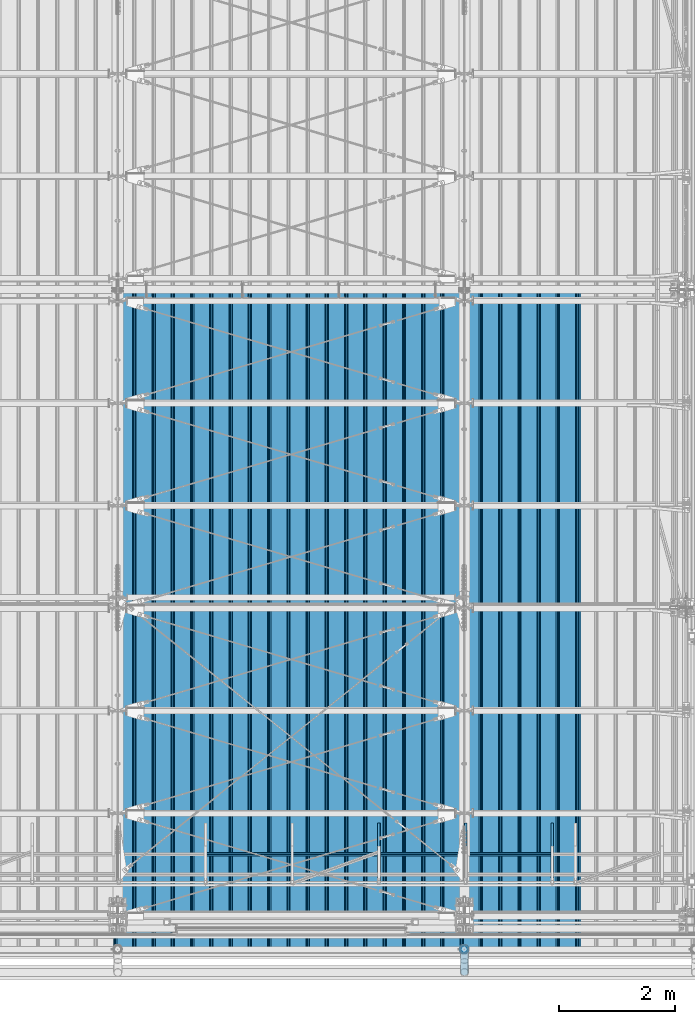
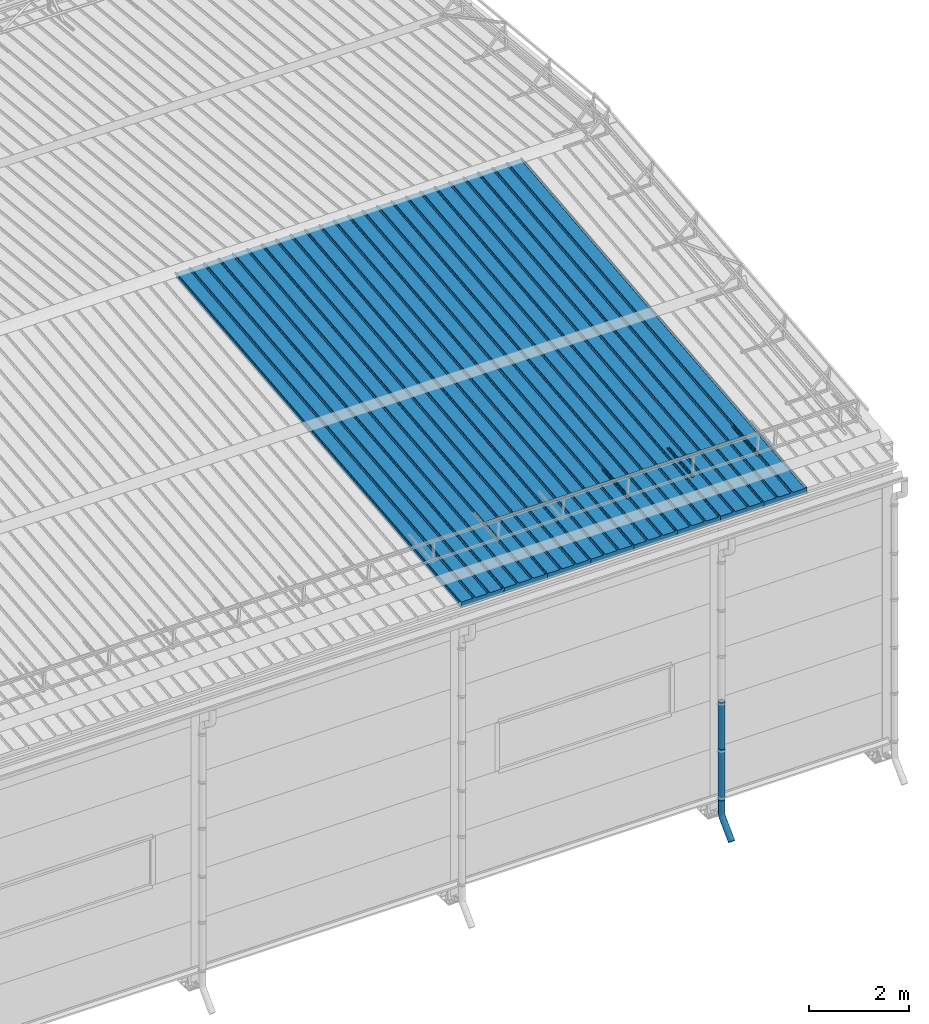
# One storey, part 68 of 709: 15 beams, 15 elements without a shape of their own.
"""IFC4 building model written with IfcOpenShell, lengths in millimetres."""

import ifcopenshell
import ifcopenshell.guid

model = None  # the IFC model being written
_history = None  # IfcOwnerHistory: only IFC2X3 demands one
_inside = {}  # id of a spatial element -> (the spatial element, [elements in it])
_under = {}  # id of a project, library or spatial element -> (it, [spatial elements below it])
_declared = {}  # id of a project -> (the project, [libraries it declares])
_typed = {}  # id of a type object -> (the type object, [elements of that type])
_made_of = {}  # id of a material, layer set ... -> (it, [elements and type objects made of it])


def new_model(schema):
    """Start an empty IFC model of exactly this schema.

    Asked for "IFC4X3", IfcOpenShell would pick the latest addendum, in which some entities
    have other attributes; the version numbers below select the first issue.
    IFC2X3 requires an IfcOwnerHistory on every rooted entity: one is made here for all.
    """
    global model, _history
    if schema == "IFC4X3":
        model = ifcopenshell.file(schema_version=(4, 3, 0, 0))
    else:
        model = ifcopenshell.file(schema=schema)
    _inside.clear()
    _under.clear()
    _declared.clear()
    _typed.clear()
    _made_of.clear()
    _history = None
    if model.schema == "IFC2X3":
        org = make("IfcOrganization", Name="unknown")
        user = make(
            "IfcPersonAndOrganization",
            ThePerson=make("IfcPerson", FamilyName="unknown"),
            TheOrganization=org,
        )
        app = make(
            "IfcApplication",
            ApplicationDeveloper=org,
            Version="unknown",
            ApplicationFullName="unknown",
            ApplicationIdentifier="unknown",
        )
        _history = make(
            "IfcOwnerHistory",
            OwningUser=user,
            OwningApplication=app,
            ChangeAction="ADDED",
            CreationDate=0,
        )
    return model


def make(cls, **values):
    """One entity of the class cls with the attributes given. An attribute that is None is left unset."""
    return model.create_entity(
        cls, **{name: value for name, value in values.items() if value is not None}
    )


def entity(cls, *values):
    """Any entity or typed value of the class cls, its attributes in the order of the schema. None: left unset."""
    e = model.create_entity(cls)
    for i, value in enumerate(values):
        if value is not None:
            e[i] = value
    return e


def rooted(cls, **values):
    """An entity with a GlobalId (a new one), such as an element, a storey or a relation."""
    return make(cls, GlobalId=ifcopenshell.guid.new(), OwnerHistory=_history, **values)


def si_unit(unit_type, name, prefix=None):
    """IfcSIUnit, for example si_unit("LENGTHUNIT", "METRE", prefix="MILLI")."""
    return make("IfcSIUnit", UnitType=unit_type, Prefix=prefix, Name=name)


def assignment(units):
    """IfcUnitAssignment: the units of a project."""
    return None if units is None else make("IfcUnitAssignment", Units=units)


def point(xyz):
    """IfcCartesianPoint."""
    return None if xyz is None else make("IfcCartesianPoint", Coordinates=xyz)


def direction(xyz):
    """IfcDirection."""
    return None if xyz is None else make("IfcDirection", DirectionRatios=xyz)


def frame(location, z_axis=None, x_axis=None):
    """IfcAxis2Placement3D, a coordinate frame: its origin and axes. An axis left out is left unset."""
    return make(
        "IfcAxis2Placement3D",
        Location=point(location),
        Axis=direction(z_axis),
        RefDirection=direction(x_axis),
    )


def origin_with_axes():
    """The frame at (0, 0, 0) with the z axis (0, 0, 1) and the x axis (1, 0, 0) written out."""
    return frame((0.0, 0.0, 0.0), z_axis=(0.0, 0.0, 1.0), x_axis=(1.0, 0.0, 0.0))


def place(relative_to, where):
    """IfcLocalPlacement: puts the frame where relative to a parent placement (None: the world)."""
    return make(
        "IfcLocalPlacement", PlacementRelTo=relative_to, RelativePlacement=where
    )


def context(
    kind, dimensions, precision=None, world=None, true_north=None, identifier=None
):
    """IfcGeometricRepresentationContext, for example the 3D "Model" context."""
    return make(
        "IfcGeometricRepresentationContext",
        ContextIdentifier=identifier,
        ContextType=kind,
        CoordinateSpaceDimension=dimensions,
        Precision=precision,
        WorldCoordinateSystem=world,
        TrueNorth=true_north,
    )


def subcontext(parent, identifier, kind, view, scale=None):
    """IfcGeometricRepresentationSubContext, for example "Body" below "Model"."""
    return make(
        "IfcGeometricRepresentationSubContext",
        ContextIdentifier=identifier,
        ContextType=kind,
        ParentContext=parent,
        TargetScale=scale,
        TargetView=view,
    )


def project(units=None, contexts=None):
    """IfcProject with its units and contexts."""
    return rooted(
        "IfcProject",
        Name="project",
        RepresentationContexts=contexts,
        UnitsInContext=assignment(units),
    )


def spatial(cls, under=None, at=None, **own):
    """A site, building, storey or space (cls), placed at a placement, below another one or the project."""
    s = rooted(cls, ObjectPlacement=at, **own)
    if under is not None:
        _under.setdefault(under.id(), (under, []))[1].append(s)
    return s


def point_list(points):
    """IfcCartesianPointList2D or 3D."""
    cls = (
        "IfcCartesianPointList2D" if len(points[0]) == 2 else "IfcCartesianPointList3D"
    )
    return make(cls, CoordList=points)


def line(*indices):
    """IfcLineIndex: a straight run through numbered points of an indexed curve."""
    return model.create_entity("IfcLineIndex", indices)


def indexed_curve(points, segments=None, self_intersect=None):
    """IfcIndexedPolyCurve: lines and arcs through numbered points (the first is 1)."""
    return make(
        "IfcIndexedPolyCurve",
        Points=point_list(points),
        Segments=segments,
        SelfIntersect=self_intersect,
    )


def outline(outer, holes=None, kind="AREA"):
    """IfcArbitraryClosedProfileDef: a profile drawn as a closed curve; with holes, ...WithVoids."""
    if holes is None:
        return make("IfcArbitraryClosedProfileDef", ProfileType=kind, OuterCurve=outer)
    return make(
        "IfcArbitraryProfileDefWithVoids",
        ProfileType=kind,
        OuterCurve=outer,
        InnerCurves=holes,
    )


def extrude(swept, where, along, depth):
    """IfcExtrudedAreaSolid: the profile swept, set in the frame where, extruded along a direction by depth."""
    return make(
        "IfcExtrudedAreaSolid",
        SweptArea=swept,
        Position=where,
        ExtrudedDirection=direction(along),
        Depth=depth,
    )


def shape(context_of_items, identifier, shape_type, items):
    """IfcShapeRepresentation: the items that make up one representation, for example the "Body"."""
    return make(
        "IfcShapeRepresentation",
        ContextOfItems=context_of_items,
        RepresentationIdentifier=identifier,
        RepresentationType=shape_type,
        Items=items,
    )


def material(Name=None, Category=None):
    """IfcMaterial."""
    return make("IfcMaterial", Name=Name, Category=Category)


def made_of(thing, what):
    """Note that an element or type object is made of a material, layer set ...; save() writes the relation."""
    if what is not None:
        _made_of.setdefault(what.id(), (what, []))[1].append(thing)
    return thing


def element(
    cls,
    number,
    at=None,
    inside=None,
    cuts=None,
    type_object=None,
    material=None,
    context=None,
    identifier="Body",
    shape_type=None,
    held_by="IfcProductDefinitionShape",
    body=None,
    shapes=None,
    **own,
):
    """One element of the class cls, such as IfcWall. Its Tag is "e" and its number.

    at: its placement. inside: the storey or other place that contains it. cuts: it is an
    opening in that element (IfcRelVoidsElement). A single representation is given by context,
    identifier, shape_type and body (its items); several are given by shapes. held_by: the class
    of the entity that holds the representations. save() writes the other relations.
    """
    e = rooted(cls, Tag="e%d" % number, ObjectPlacement=at, **own)
    if body is not None:
        shapes = [shape(context, identifier, shape_type, body)]
    if shapes is not None:
        e.Representation = make(held_by, Representations=shapes)
    if inside is not None:
        _inside.setdefault(inside.id(), (inside, []))[1].append(e)
    if cuts is not None:
        rooted(
            "IfcRelVoidsElement", RelatingBuildingElement=cuts, RelatedOpeningElement=e
        )
    if type_object is not None:
        _typed.setdefault(type_object.id(), (type_object, []))[1].append(e)
    return made_of(e, material)


def aggregate(whole, parts):
    """IfcRelAggregates: a whole, such as a stair, and the parts it consists of."""
    return rooted("IfcRelAggregates", RelatingObject=whole, RelatedObjects=parts)


def save(model, path):
    """Write the relations noted so far, then the file.

    IfcRelAggregates (storeys below a building ...), IfcRelContainedInSpatialStructure (elements
    in a storey), IfcRelDefinesByType, IfcRelAssociatesMaterial and IfcRelDeclares: one each for
    every whole, place, type object, material and project.
    """
    for whole, parts in _under.values():
        aggregate(whole, parts)
    for where, things in _inside.values():
        rooted(
            "IfcRelContainedInSpatialStructure",
            RelatedElements=things,
            RelatingStructure=where,
        )
    for kind, things in _typed.values():
        rooted("IfcRelDefinesByType", RelatedObjects=things, RelatingType=kind)
    for what, things in _made_of.values():
        rooted("IfcRelAssociatesMaterial", RelatedObjects=things, RelatingMaterial=what)
    for by, libraries in _declared.values():
        rooted("IfcRelDeclares", RelatingContext=by, RelatedDefinitions=libraries)
    model.write(path)


model = new_model("IFC4")

# Units and contexts
model_context = context("Model", 3, precision=0.2, world=origin_with_axes(), true_north=direction((0.0, 1.0)))
body_context = subcontext(model_context, "Body", "Model", "MODEL_VIEW")
ifc_project = project(units=[si_unit("LENGTHUNIT", "METRE", prefix="MILLI"), si_unit("AREAUNIT", "SQUARE_METRE"), si_unit("VOLUMEUNIT", "CUBIC_METRE"), si_unit("MASSUNIT", "GRAM", prefix="KILO"), si_unit("TIMEUNIT", "SECOND"), si_unit("PLANEANGLEUNIT", "RADIAN"), si_unit("SOLIDANGLEUNIT", "STERADIAN"), si_unit("THERMODYNAMICTEMPERATUREUNIT", "DEGREE_CELSIUS"), si_unit("LUMINOUSINTENSITYUNIT", "LUMEN")], contexts=[model_context])

# Site, building, storey
site_placement = place(None, origin_with_axes())
site = spatial("IfcSite", under=ifc_project, at=site_placement, CompositionType="ELEMENT")
building_placement = place(site_placement, origin_with_axes())
building = spatial("IfcBuilding", under=site, at=building_placement, Name="Undefined", CompositionType="ELEMENT")
storey_placement = place(building_placement, origin_with_axes())
storey = spatial("IfcBuildingStorey", under=building, at=storey_placement, Name="Undefined", CompositionType="ELEMENT", Elevation=0.0)

# Assembly, beam
assembly_1_placement = place(storey_placement, frame((47452.44, -410.89541, 7279.78979), z_axis=(1.0, 0.0, 0.0), x_axis=(0.0, 0.9950371902, 0.099503719)))
assembly_1 = element("IfcElementAssembly", 1, at=assembly_1_placement, inside=storey)
ifc_material_1 = material(Name="Insulation", Category="Insulation")
beam_1_placement = place(assembly_1_placement, origin_with_axes())
beam_1 = element("IfcBeam", 2, at=beam_1_placement, material=ifc_material_1, ObjectType="P-99", context=body_context, shape_type="SolidModel", body=[
    extrude(outline(indexed_curve([(-509.8453, 89.5), (-490.1547, 89.5), (-471.67949, 57.5), (-471.67949, -88.5), (-436.67949, -88.5), (-436.67949, -91.5), (562.55841, -91.5), (562.55841, -89.5), (527.55841, -89.5), (527.55841, 57.5), (510.2379, 88.5), (489.7621, 88.5), (472.44159, 58.5), (196.71923, 58.5), (177.66667, 91.5), (155.66667, 91.5), (136.61411, 58.5), (-136.61411, 58.5), (-155.66667, 91.5), (-177.66667, 91.5), (-196.71923, 58.5), (-469.94744, 58.5), (-489.0, 91.5), (-511.0, 91.5), (-527.16581, 63.5), (-525.43376, 62.5)], segments=[line(1, 2, 3, 4, 5, 6, 7, 8, 9, 10, 11, 12, 13, 14, 15, 16, 17, 18, 19, 20, 21, 22, 23, 24, 25, 26, 1)])), frame((0.0, 0.0, 0.0), z_axis=(-1.0, 0.0, 0.0), x_axis=(0.0, 0.0, 1.0)), (0.0, 0.0, -1.0), 11459.0),
])
aggregate(assembly_1, [beam_1])

assembly_2_placement = place(storey_placement, frame((46452.44, -410.89541, 7279.78979), z_axis=(1.0, 0.0, 0.0), x_axis=(0.0, 0.9950371902, 0.099503719)))
assembly_2 = element("IfcElementAssembly", 3, at=assembly_2_placement, inside=storey)
beam_2_placement = place(assembly_2_placement, origin_with_axes())
beam_2 = element("IfcBeam", 4, at=beam_2_placement, material=ifc_material_1, ObjectType="P-99", context=body_context, shape_type="SolidModel", body=[
    extrude(outline(indexed_curve([(-509.8453, 89.5), (-490.1547, 89.5), (-471.67949, 57.5), (-471.67949, -88.5), (-436.67949, -88.5), (-436.67949, -91.5), (562.55841, -91.5), (562.55841, -89.5), (527.55841, -89.5), (527.55841, 57.5), (510.2379, 88.5), (489.7621, 88.5), (472.44159, 58.5), (196.71923, 58.5), (177.66667, 91.5), (155.66667, 91.5), (136.61411, 58.5), (-136.61411, 58.5), (-155.66667, 91.5), (-177.66667, 91.5), (-196.71923, 58.5), (-469.94744, 58.5), (-489.0, 91.5), (-511.0, 91.5), (-527.16581, 63.5), (-525.43376, 62.5)], segments=[line(1, 2, 3, 4, 5, 6, 7, 8, 9, 10, 11, 12, 13, 14, 15, 16, 17, 18, 19, 20, 21, 22, 23, 24, 25, 26, 1)])), frame((0.0, 0.0, 0.0), z_axis=(-1.0, 0.0, 0.0), x_axis=(0.0, 0.0, 1.0)), (0.0, 0.0, -1.0), 11459.0),
])
aggregate(assembly_2, [beam_2])

assembly_3_placement = place(storey_placement, frame((45452.44, -410.89541, 7279.78979), z_axis=(1.0, 0.0, 0.0), x_axis=(0.0, 0.9950371902, 0.099503719)))
assembly_3 = element("IfcElementAssembly", 5, at=assembly_3_placement, inside=storey)
beam_3_placement = place(assembly_3_placement, origin_with_axes())
beam_3 = element("IfcBeam", 6, at=beam_3_placement, material=ifc_material_1, ObjectType="P-99", context=body_context, shape_type="SolidModel", body=[
    extrude(outline(indexed_curve([(-509.8453, 89.5), (-490.1547, 89.5), (-471.67949, 57.5), (-471.67949, -88.5), (-436.67949, -88.5), (-436.67949, -91.5), (562.55841, -91.5), (562.55841, -89.5), (527.55841, -89.5), (527.55841, 57.5), (510.2379, 88.5), (489.7621, 88.5), (472.44159, 58.5), (196.71923, 58.5), (177.66667, 91.5), (155.66667, 91.5), (136.61411, 58.5), (-136.61411, 58.5), (-155.66667, 91.5), (-177.66667, 91.5), (-196.71923, 58.5), (-469.94744, 58.5), (-489.0, 91.5), (-511.0, 91.5), (-527.16581, 63.5), (-525.43376, 62.5)], segments=[line(1, 2, 3, 4, 5, 6, 7, 8, 9, 10, 11, 12, 13, 14, 15, 16, 17, 18, 19, 20, 21, 22, 23, 24, 25, 26, 1)])), frame((0.0, 0.0, 0.0), z_axis=(-1.0, 0.0, 0.0), x_axis=(0.0, 0.0, 1.0)), (0.0, 0.0, -1.0), 11459.0),
])
aggregate(assembly_3, [beam_3])

assembly_4_placement = place(storey_placement, frame((44452.44, -410.89541, 7279.78979), z_axis=(1.0, 0.0, 0.0), x_axis=(0.0, 0.9950371902, 0.099503719)))
assembly_4 = element("IfcElementAssembly", 7, at=assembly_4_placement, inside=storey)
beam_4_placement = place(assembly_4_placement, origin_with_axes())
beam_4 = element("IfcBeam", 8, at=beam_4_placement, material=ifc_material_1, ObjectType="P-99", context=body_context, shape_type="SolidModel", body=[
    extrude(outline(indexed_curve([(-509.8453, 89.5), (-490.1547, 89.5), (-471.67949, 57.5), (-471.67949, -88.5), (-436.67949, -88.5), (-436.67949, -91.5), (562.55841, -91.5), (562.55841, -89.5), (527.55841, -89.5), (527.55841, 57.5), (510.2379, 88.5), (489.7621, 88.5), (472.44159, 58.5), (196.71923, 58.5), (177.66667, 91.5), (155.66667, 91.5), (136.61411, 58.5), (-136.61411, 58.5), (-155.66667, 91.5), (-177.66667, 91.5), (-196.71923, 58.5), (-469.94744, 58.5), (-489.0, 91.5), (-511.0, 91.5), (-527.16581, 63.5), (-525.43376, 62.5)], segments=[line(1, 2, 3, 4, 5, 6, 7, 8, 9, 10, 11, 12, 13, 14, 15, 16, 17, 18, 19, 20, 21, 22, 23, 24, 25, 26, 1)])), frame((0.0, 0.0, 0.0), z_axis=(-1.0, 0.0, 0.0), x_axis=(0.0, 0.0, 1.0)), (0.0, 0.0, -1.0), 11459.0),
])
aggregate(assembly_4, [beam_4])

assembly_5_placement = place(storey_placement, frame((43452.44, -410.89541, 7279.78979), z_axis=(1.0, 0.0, 0.0), x_axis=(0.0, 0.9950371902, 0.099503719)))
assembly_5 = element("IfcElementAssembly", 9, at=assembly_5_placement, inside=storey)
beam_5_placement = place(assembly_5_placement, origin_with_axes())
beam_5 = element("IfcBeam", 10, at=beam_5_placement, material=ifc_material_1, ObjectType="P-99", context=body_context, shape_type="SolidModel", body=[
    extrude(outline(indexed_curve([(-509.8453, 89.5), (-490.1547, 89.5), (-471.67949, 57.5), (-471.67949, -88.5), (-436.67949, -88.5), (-436.67949, -91.5), (562.55841, -91.5), (562.55841, -89.5), (527.55841, -89.5), (527.55841, 57.5), (510.2379, 88.5), (489.7621, 88.5), (472.44159, 58.5), (196.71923, 58.5), (177.66667, 91.5), (155.66667, 91.5), (136.61411, 58.5), (-136.61411, 58.5), (-155.66667, 91.5), (-177.66667, 91.5), (-196.71923, 58.5), (-469.94744, 58.5), (-489.0, 91.5), (-511.0, 91.5), (-527.16581, 63.5), (-525.43376, 62.5)], segments=[line(1, 2, 3, 4, 5, 6, 7, 8, 9, 10, 11, 12, 13, 14, 15, 16, 17, 18, 19, 20, 21, 22, 23, 24, 25, 26, 1)])), frame((0.0, 0.0, 0.0), z_axis=(-1.0, 0.0, 0.0), x_axis=(0.0, 0.0, 1.0)), (0.0, 0.0, -1.0), 11459.0),
])
aggregate(assembly_5, [beam_5])

assembly_6_placement = place(storey_placement, frame((42452.44, -410.89541, 7279.78979), z_axis=(1.0, 0.0, 0.0), x_axis=(0.0, 0.9950371902, 0.099503719)))
assembly_6 = element("IfcElementAssembly", 11, at=assembly_6_placement, inside=storey)
beam_6_placement = place(assembly_6_placement, origin_with_axes())
beam_6 = element("IfcBeam", 12, at=beam_6_placement, material=ifc_material_1, ObjectType="P-99", context=body_context, shape_type="SolidModel", body=[
    extrude(outline(indexed_curve([(-509.8453, 89.5), (-490.1547, 89.5), (-471.67949, 57.5), (-471.67949, -88.5), (-436.67949, -88.5), (-436.67949, -91.5), (562.55841, -91.5), (562.55841, -89.5), (527.55841, -89.5), (527.55841, 57.5), (510.2379, 88.5), (489.7621, 88.5), (472.44159, 58.5), (196.71923, 58.5), (177.66667, 91.5), (155.66667, 91.5), (136.61411, 58.5), (-136.61411, 58.5), (-155.66667, 91.5), (-177.66667, 91.5), (-196.71923, 58.5), (-469.94744, 58.5), (-489.0, 91.5), (-511.0, 91.5), (-527.16581, 63.5), (-525.43376, 62.5)], segments=[line(1, 2, 3, 4, 5, 6, 7, 8, 9, 10, 11, 12, 13, 14, 15, 16, 17, 18, 19, 20, 21, 22, 23, 24, 25, 26, 1)])), frame((0.0, 0.0, 0.0), z_axis=(-1.0, 0.0, 0.0), x_axis=(0.0, 0.0, 1.0)), (0.0, 0.0, -1.0), 11459.0),
])
aggregate(assembly_6, [beam_6])

assembly_7_placement = place(storey_placement, frame((41452.44, -410.89541, 7279.78979), z_axis=(1.0, 0.0, 0.0), x_axis=(0.0, 0.9950371902, 0.099503719)))
assembly_7 = element("IfcElementAssembly", 13, at=assembly_7_placement, inside=storey)
beam_7_placement = place(assembly_7_placement, origin_with_axes())
beam_7 = element("IfcBeam", 14, at=beam_7_placement, material=ifc_material_1, ObjectType="P-99", context=body_context, shape_type="SolidModel", body=[
    extrude(outline(indexed_curve([(-509.8453, 89.5), (-490.1547, 89.5), (-471.67949, 57.5), (-471.67949, -88.5), (-436.67949, -88.5), (-436.67949, -91.5), (562.55841, -91.5), (562.55841, -89.5), (527.55841, -89.5), (527.55841, 57.5), (510.2379, 88.5), (489.7621, 88.5), (472.44159, 58.5), (196.71923, 58.5), (177.66667, 91.5), (155.66667, 91.5), (136.61411, 58.5), (-136.61411, 58.5), (-155.66667, 91.5), (-177.66667, 91.5), (-196.71923, 58.5), (-469.94744, 58.5), (-489.0, 91.5), (-511.0, 91.5), (-527.16581, 63.5), (-525.43376, 62.5)], segments=[line(1, 2, 3, 4, 5, 6, 7, 8, 9, 10, 11, 12, 13, 14, 15, 16, 17, 18, 19, 20, 21, 22, 23, 24, 25, 26, 1)])), frame((0.0, 0.0, 0.0), z_axis=(-1.0, 0.0, 0.0), x_axis=(0.0, 0.0, 1.0)), (0.0, 0.0, -1.0), 11459.0),
])
aggregate(assembly_7, [beam_7])

assembly_8_placement = place(storey_placement, frame((40452.44, -410.89541, 7279.78979), z_axis=(1.0, 0.0, 0.0), x_axis=(0.0, 0.9950371902, 0.099503719)))
assembly_8 = element("IfcElementAssembly", 15, at=assembly_8_placement, inside=storey)
beam_8_placement = place(assembly_8_placement, origin_with_axes())
beam_8 = element("IfcBeam", 16, at=beam_8_placement, material=ifc_material_1, ObjectType="P-99", context=body_context, shape_type="SolidModel", body=[
    extrude(outline(indexed_curve([(-509.8453, 89.5), (-490.1547, 89.5), (-471.67949, 57.5), (-471.67949, -88.5), (-436.67949, -88.5), (-436.67949, -91.5), (562.55841, -91.5), (562.55841, -89.5), (527.55841, -89.5), (527.55841, 57.5), (510.2379, 88.5), (489.7621, 88.5), (472.44159, 58.5), (196.71923, 58.5), (177.66667, 91.5), (155.66667, 91.5), (136.61411, 58.5), (-136.61411, 58.5), (-155.66667, 91.5), (-177.66667, 91.5), (-196.71923, 58.5), (-469.94744, 58.5), (-489.0, 91.5), (-511.0, 91.5), (-527.16581, 63.5), (-525.43376, 62.5)], segments=[line(1, 2, 3, 4, 5, 6, 7, 8, 9, 10, 11, 12, 13, 14, 15, 16, 17, 18, 19, 20, 21, 22, 23, 24, 25, 26, 1)])), frame((0.0, 0.0, 0.0), z_axis=(-1.0, 0.0, 0.0), x_axis=(0.0, 0.0, 1.0)), (0.0, 0.0, -1.0), 11459.0),
])
aggregate(assembly_8, [beam_8])

assembly_9_placement = place(storey_placement, frame((44520.0, 768.92298, 7577.16191), z_axis=(0.0, -0.099503719, 0.9950371902), x_axis=(0.0, 0.9950371902, 0.099503719)))
assembly_9 = element("IfcElementAssembly", 17, at=assembly_9_placement, inside=storey)
ifc_material_2 = material(Name="Steel_Undefined", Category="STEEL")
beam_9_placement = place(assembly_9_placement, origin_with_axes())
beam_9 = element("IfcBeam", 18, at=beam_9_placement, material=ifc_material_2, ObjectType="601", context=body_context, shape_type="SolidModel", body=[
    extrude(outline(indexed_curve([(-20.0, -25.0), (20.0, -25.0), (20.0, -22.5), (-17.5, -22.5), (-17.5, 22.5), (20.0, 22.5), (20.0, 25.0), (-20.0, 25.0)], segments=[line(1, 2, 3, 4, 5, 6, 7, 8, 1)])), frame((0.0, 0.0, 0.0), z_axis=(-1.0, 0.0, 0.0), x_axis=(0.0, 0.0, 1.0)), (0.0, 0.0, -1.0), 1000.0),
])
aggregate(assembly_9, [beam_9])

assembly_10_placement = place(storey_placement, frame((46020.0, 768.92298, 7577.16191), z_axis=(0.0, -0.099503719, 0.9950371902), x_axis=(0.0, 0.9950371902, 0.099503719)))
assembly_10 = element("IfcElementAssembly", 19, at=assembly_10_placement, inside=storey)
beam_10_placement = place(assembly_10_placement, origin_with_axes())
beam_10 = element("IfcBeam", 20, at=beam_10_placement, material=ifc_material_2, ObjectType="601", context=body_context, shape_type="SolidModel", body=[
    extrude(outline(indexed_curve([(-20.0, -25.0), (20.0, -25.0), (20.0, -22.5), (-17.5, -22.5), (-17.5, 22.5), (20.0, 22.5), (20.0, 25.0), (-20.0, 25.0)], segments=[line(1, 2, 3, 4, 5, 6, 7, 8, 1)])), frame((0.0, 0.0, 0.0), z_axis=(-1.0, 0.0, 0.0), x_axis=(0.0, 0.0, 1.0)), (0.0, 0.0, -1.0), 1000.0),
])
aggregate(assembly_10, [beam_10])

assembly_11_placement = place(storey_placement, frame((41520.0, 1225.80867, 7759.0901), z_axis=(0.0, 0.6332377902, 0.7739572992), x_axis=(1.0, 0.0, 0.0)))
assembly_11 = element("IfcElementAssembly", 21, at=assembly_11_placement, inside=storey)
beam_11_placement = place(assembly_11_placement, origin_with_axes())
beam_11 = element("IfcBeam", 22, at=beam_11_placement, material=ifc_material_2, ObjectType="606", context=body_context, shape_type="SolidModel", body=[
    extrude(outline(indexed_curve([(-20.0, -25.0), (20.0, -25.0), (20.0, -22.5), (-17.5, -22.5), (-17.5, 22.5), (20.0, 22.5), (20.0, 25.0), (-20.0, 25.0)], segments=[line(1, 2, 3, 4, 5, 6, 7, 8, 1)])), frame((0.0, 0.0, 0.0), z_axis=(-1.0, 0.0, 0.0), x_axis=(0.0, 0.0, 1.0)), (0.0, 0.0, -1.0), 6000.0),
])
aggregate(assembly_11, [beam_11])

assembly_12_placement = place(storey_placement, frame((47520.0, 768.92298, 7577.16191), z_axis=(0.0, -0.099503719, 0.9950371902), x_axis=(0.0, 0.9950371902, 0.099503719)))
assembly_12 = element("IfcElementAssembly", 23, at=assembly_12_placement, inside=storey)
beam_12_placement = place(assembly_12_placement, origin_with_axes())
beam_12 = element("IfcBeam", 24, at=beam_12_placement, material=ifc_material_2, ObjectType="601", context=body_context, shape_type="SolidModel", body=[
    extrude(outline(indexed_curve([(-20.0, -25.0), (20.0, -25.0), (20.0, -22.5), (-17.5, -22.5), (-17.5, 22.5), (20.0, 22.5), (20.0, 25.0), (-20.0, 25.0)], segments=[line(1, 2, 3, 4, 5, 6, 7, 8, 1)])), frame((0.0, 0.0, 0.0), z_axis=(-1.0, 0.0, 0.0), x_axis=(0.0, 0.0, 1.0)), (0.0, 0.0, -1.0), 1000.0),
])
aggregate(assembly_12, [beam_12])

assembly_13_placement = place(storey_placement, frame((46000.0, -420.0, 2826.92297), z_axis=(0.0, 1.0, 0.0), x_axis=(0.0, 0.0, -1.0)))
assembly_13 = element("IfcElementAssembly", 25, at=assembly_13_placement, inside=storey)
beam_13_placement = place(assembly_13_placement, origin_with_axes())
beam_13 = element("IfcBeam", 26, at=beam_13_placement, material=ifc_material_2, ObjectType="614", context=body_context, shape_type="SolidModel", body=[
    extrude(outline(indexed_curve([(70.0, 0.0), (69.61653, 7.31699), (68.47033, 14.55382), (66.57396, 21.63119), (63.94818, 28.47157), (60.62178, 35.0), (56.63119, 41.14497), (52.02014, 46.83914), (46.83914, 52.02014), (41.14497, 56.63119), (35.0, 60.62178), (28.47157, 63.94818), (21.63119, 66.57396), (14.55382, 68.47033), (7.31699, 69.61653), (0.0, 70.0), (-7.31699, 69.61653), (-14.55382, 68.47033), (-21.63119, 66.57396), (-28.47157, 63.94818), (-35.0, 60.62178), (-41.14497, 56.63119), (-46.83914, 52.02014), (-52.02014, 46.83914), (-56.63119, 41.14497), (-60.62178, 35.0), (-63.94818, 28.47157), (-66.57396, 21.63119), (-68.47033, 14.55382), (-69.61653, 7.31699), (-70.0, 0.0), (-69.61653, -7.31699), (-68.47033, -14.55382), (-66.57396, -21.63119), (-63.94818, -28.47157), (-60.62178, -35.0), (-56.63119, -41.14497), (-52.02014, -46.83914), (-46.83914, -52.02014), (-41.14497, -56.63119), (-35.0, -60.62178), (-28.47157, -63.94818), (-21.63119, -66.57396), (-14.55382, -68.47033), (-7.31699, -69.61653), (0.0, -70.0), (7.31699, -69.61653), (14.55382, -68.47033), (21.63119, -66.57396), (28.47157, -63.94818), (35.0, -60.62178), (41.14497, -56.63119), (46.83914, -52.02014), (52.02014, -46.83914), (56.63119, -41.14497), (60.62178, -35.0), (63.94818, -28.47157), (66.57396, -21.63119), (68.47033, -14.55382), (69.61653, -7.31699)], segments=[line(1, 2, 3, 4, 5, 6, 7, 8, 9, 10, 11, 12, 13, 14, 15, 16, 17, 18, 19, 20, 21, 22, 23, 24, 25, 26, 27, 28, 29, 30, 31, 32, 33, 34, 35, 36, 37, 38, 39, 40, 41, 42, 43, 44, 45, 46, 47, 48, 49, 50, 51, 52, 53, 54, 55, 56, 57, 58, 59, 60, 1)]), holes=[indexed_curve([(65.0, 0.0), (64.64392, -6.79435), (63.57959, -13.51426), (61.81867, -20.0861), (59.38045, -26.43788), (56.29165, -32.5), (52.5861, -38.20604), (48.30441, -43.49349), (43.49349, -48.30441), (38.20604, -52.5861), (32.5, -56.29165), (26.43788, -59.38045), (20.0861, -61.81867), (13.51426, -63.57959), (6.79435, -64.64392), (0.0, -65.0), (-6.79435, -64.64392), (-13.51426, -63.57959), (-20.0861, -61.81867), (-26.43788, -59.38045), (-32.5, -56.29165), (-38.20604, -52.5861), (-43.49349, -48.30441), (-48.30441, -43.49349), (-52.5861, -38.20604), (-56.29165, -32.5), (-59.38045, -26.43788), (-61.81867, -20.0861), (-63.57959, -13.51426), (-64.64392, -6.79435), (-65.0, 0.0), (-64.64392, 6.79435), (-63.57959, 13.51426), (-61.81867, 20.0861), (-59.38045, 26.43788), (-56.29165, 32.5), (-52.5861, 38.20604), (-48.30441, 43.49349), (-43.49349, 48.30441), (-38.20604, 52.5861), (-32.5, 56.29165), (-26.43788, 59.38045), (-20.0861, 61.81867), (-13.51426, 63.57959), (-6.79435, 64.64392), (0.0, 65.0), (6.79435, 64.64392), (13.51426, 63.57959), (20.0861, 61.81867), (26.43788, 59.38045), (32.5, 56.29165), (38.20604, 52.5861), (43.49349, 48.30441), (48.30441, 43.49349), (52.5861, 38.20604), (56.29165, 32.5), (59.38045, 26.43788), (61.81867, 20.0861), (63.57959, 13.51426), (64.64392, 6.79435)], segments=[line(1, 2, 3, 4, 5, 6, 7, 8, 9, 10, 11, 12, 13, 14, 15, 16, 17, 18, 19, 20, 21, 22, 23, 24, 25, 26, 27, 28, 29, 30, 31, 32, 33, 34, 35, 36, 37, 38, 39, 40, 41, 42, 43, 44, 45, 46, 47, 48, 49, 50, 51, 52, 53, 54, 55, 56, 57, 58, 59, 60, 1)])]), frame((0.0, 0.0, 0.0), z_axis=(-1.0, 0.0, 0.0), x_axis=(0.0, 0.0, 1.0)), (0.0, 0.0, -1.0), 1250.0),
])
aggregate(assembly_13, [beam_13])

assembly_14_placement = place(storey_placement, frame((46000.0, -420.0, 1676.92297), z_axis=(0.0, 1.0, 0.0), x_axis=(0.0, 0.0, -1.0)))
assembly_14 = element("IfcElementAssembly", 27, at=assembly_14_placement, inside=storey)
beam_14_placement = place(assembly_14_placement, origin_with_axes())
beam_14 = element("IfcBeam", 28, at=beam_14_placement, material=ifc_material_2, ObjectType="614", context=body_context, shape_type="SolidModel", body=[
    extrude(outline(indexed_curve([(70.0, 0.0), (69.61653, 7.31699), (68.47033, 14.55382), (66.57396, 21.63119), (63.94818, 28.47157), (60.62178, 35.0), (56.63119, 41.14497), (52.02014, 46.83914), (46.83914, 52.02014), (41.14497, 56.63119), (35.0, 60.62178), (28.47157, 63.94818), (21.63119, 66.57396), (14.55382, 68.47033), (7.31699, 69.61653), (0.0, 70.0), (-7.31699, 69.61653), (-14.55382, 68.47033), (-21.63119, 66.57396), (-28.47157, 63.94818), (-35.0, 60.62178), (-41.14497, 56.63119), (-46.83914, 52.02014), (-52.02014, 46.83914), (-56.63119, 41.14497), (-60.62178, 35.0), (-63.94818, 28.47157), (-66.57396, 21.63119), (-68.47033, 14.55382), (-69.61653, 7.31699), (-70.0, 0.0), (-69.61653, -7.31699), (-68.47033, -14.55382), (-66.57396, -21.63119), (-63.94818, -28.47157), (-60.62178, -35.0), (-56.63119, -41.14497), (-52.02014, -46.83914), (-46.83914, -52.02014), (-41.14497, -56.63119), (-35.0, -60.62178), (-28.47157, -63.94818), (-21.63119, -66.57396), (-14.55382, -68.47033), (-7.31699, -69.61653), (0.0, -70.0), (7.31699, -69.61653), (14.55382, -68.47033), (21.63119, -66.57396), (28.47157, -63.94818), (35.0, -60.62178), (41.14497, -56.63119), (46.83914, -52.02014), (52.02014, -46.83914), (56.63119, -41.14497), (60.62178, -35.0), (63.94818, -28.47157), (66.57396, -21.63119), (68.47033, -14.55382), (69.61653, -7.31699)], segments=[line(1, 2, 3, 4, 5, 6, 7, 8, 9, 10, 11, 12, 13, 14, 15, 16, 17, 18, 19, 20, 21, 22, 23, 24, 25, 26, 27, 28, 29, 30, 31, 32, 33, 34, 35, 36, 37, 38, 39, 40, 41, 42, 43, 44, 45, 46, 47, 48, 49, 50, 51, 52, 53, 54, 55, 56, 57, 58, 59, 60, 1)]), holes=[indexed_curve([(65.0, 0.0), (64.64392, -6.79435), (63.57959, -13.51426), (61.81867, -20.0861), (59.38045, -26.43788), (56.29165, -32.5), (52.5861, -38.20604), (48.30441, -43.49349), (43.49349, -48.30441), (38.20604, -52.5861), (32.5, -56.29165), (26.43788, -59.38045), (20.0861, -61.81867), (13.51426, -63.57959), (6.79435, -64.64392), (0.0, -65.0), (-6.79435, -64.64392), (-13.51426, -63.57959), (-20.0861, -61.81867), (-26.43788, -59.38045), (-32.5, -56.29165), (-38.20604, -52.5861), (-43.49349, -48.30441), (-48.30441, -43.49349), (-52.5861, -38.20604), (-56.29165, -32.5), (-59.38045, -26.43788), (-61.81867, -20.0861), (-63.57959, -13.51426), (-64.64392, -6.79435), (-65.0, 0.0), (-64.64392, 6.79435), (-63.57959, 13.51426), (-61.81867, 20.0861), (-59.38045, 26.43788), (-56.29165, 32.5), (-52.5861, 38.20604), (-48.30441, 43.49349), (-43.49349, 48.30441), (-38.20604, 52.5861), (-32.5, 56.29165), (-26.43788, 59.38045), (-20.0861, 61.81867), (-13.51426, 63.57959), (-6.79435, 64.64392), (0.0, 65.0), (6.79435, 64.64392), (13.51426, 63.57959), (20.0861, 61.81867), (26.43788, 59.38045), (32.5, 56.29165), (38.20604, 52.5861), (43.49349, 48.30441), (48.30441, 43.49349), (52.5861, 38.20604), (56.29165, 32.5), (59.38045, 26.43788), (61.81867, 20.0861), (63.57959, 13.51426), (64.64392, 6.79435)], segments=[line(1, 2, 3, 4, 5, 6, 7, 8, 9, 10, 11, 12, 13, 14, 15, 16, 17, 18, 19, 20, 21, 22, 23, 24, 25, 26, 27, 28, 29, 30, 31, 32, 33, 34, 35, 36, 37, 38, 39, 40, 41, 42, 43, 44, 45, 46, 47, 48, 49, 50, 51, 52, 53, 54, 55, 56, 57, 58, 59, 60, 1)])]), frame((0.0, 0.0, 0.0), z_axis=(-1.0, 0.0, 0.0), x_axis=(0.0, 0.0, 1.0)), (0.0, 0.0, -1.0), 1250.0),
])
aggregate(assembly_14, [beam_14])

assembly_15_placement = place(storey_placement, frame((46000.0, -420.0, 526.92297), z_axis=(-1.0, 0.0, 0.0), x_axis=(0.0, 0.0, -1.0)))
assembly_15 = element("IfcElementAssembly", 29, at=assembly_15_placement, inside=storey)
beam_15_placement = place(assembly_15_placement, origin_with_axes())
beam_15 = element("IfcBeam", 30, at=beam_15_placement, material=ifc_material_2, ObjectType="617", context=body_context, shape_type="SolidModel", body=[
    entity("IfcSweptDiskSolid", entity("IfcIndexedPolyCurve", entity("IfcCartesianPointList3D", [[0.0, 0.0, 0.0], [448.2233, 0.0, 0.0], [496.05873, 9.51506, 0.0], [536.61165, 36.61165, 0.0], [900.0, 400.0, 0.0]]), [entity("IfcLineIndex", [1, 2]), entity("IfcArcIndex", [2, 3, 4]), entity("IfcLineIndex", [4, 5])]), 70.0, 65.0),
])
aggregate(assembly_15, [beam_15])

save(model, "model.ifc")
